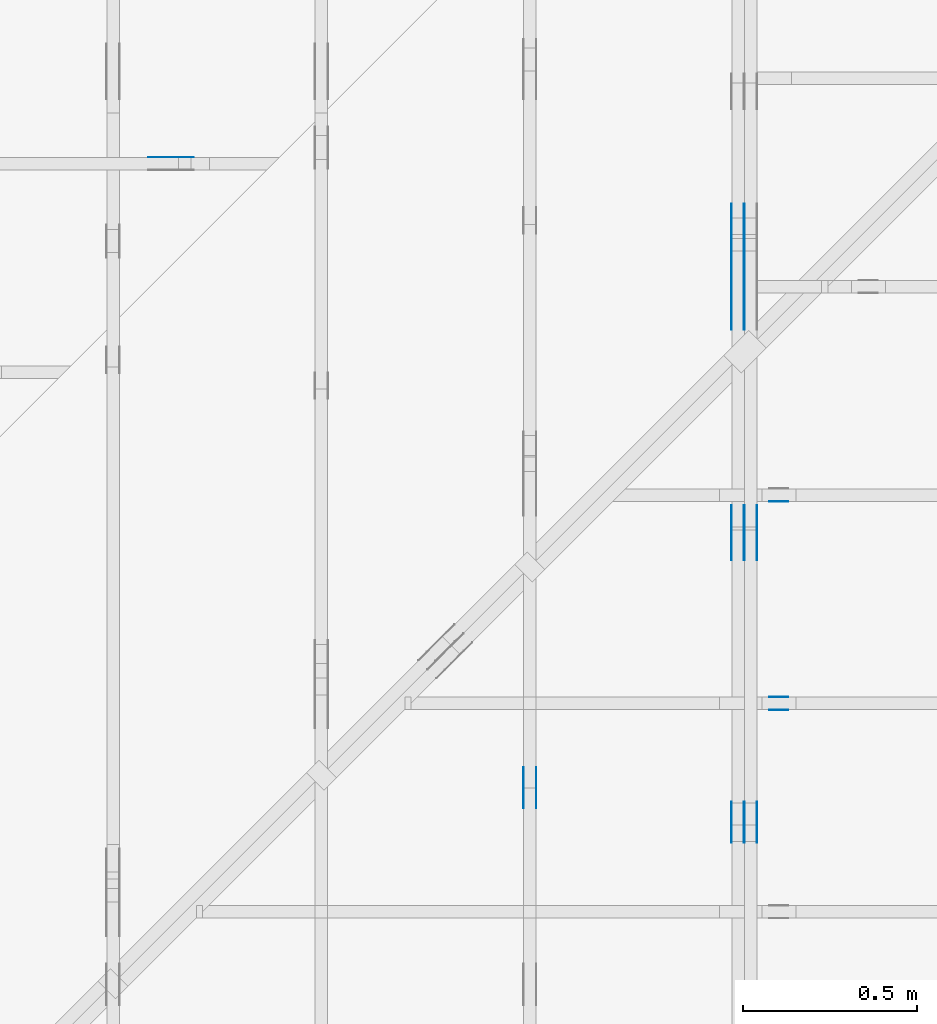
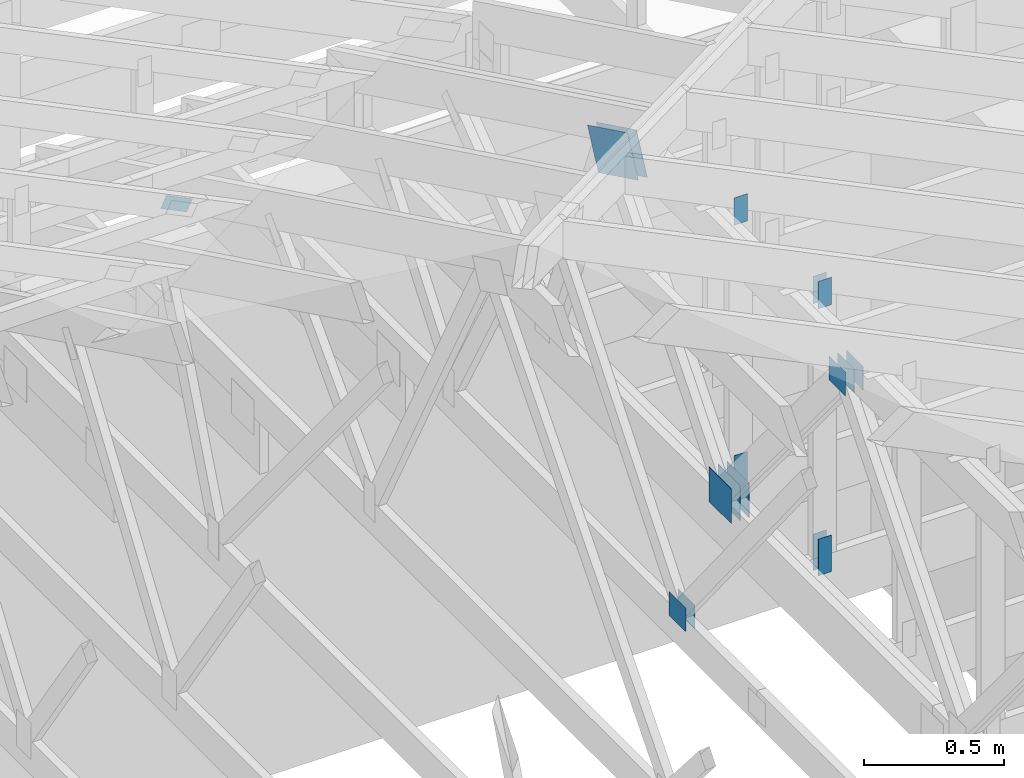
# One storey, part 123 of 159: 20 plates, 5 elements without a shape of their own.
"""IFC2X3 building model written with IfcOpenShell, lengths in millimetres."""

from ifc_helpers import new_model, si_unit, frame, origin, origin_with_axes, origin_2d, place, context, project, spatial, faceted_brep, element, aggregate, save


model = new_model("IFC2X3")

# Units and contexts
model_context = context("Model", 3, precision=1e-05, world=origin())
plan_context = context("Plan", 2, precision=1e-05, world=origin_2d())
ifc_project = project(units=[si_unit("LENGTHUNIT", "METRE", prefix="MILLI"), si_unit("AREAUNIT", "SQUARE_METRE"), si_unit("VOLUMEUNIT", "CUBIC_METRE"), si_unit("SOLIDANGLEUNIT", "STERADIAN"), si_unit("PLANEANGLEUNIT", "RADIAN"), si_unit("MASSUNIT", "GRAM"), si_unit("TIMEUNIT", "SECOND"), si_unit("THERMODYNAMICTEMPERATUREUNIT", "DEGREE_CELSIUS"), si_unit("LUMINOUSINTENSITYUNIT", "LUMEN")], contexts=[model_context, plan_context])

# Site, building, storey
site_placement = place(None, origin_with_axes())
site = spatial("IfcSite", under=ifc_project, at=site_placement, CompositionType="ELEMENT")
building_placement = place(site_placement, origin_with_axes())
building = spatial("IfcBuilding", under=site, at=building_placement, Name="Plan 1", CompositionType="ELEMENT")
storey_placement = place(building_placement, origin_with_axes())
storey = spatial("IfcBuildingStorey", under=building, at=storey_placement, Name="Etasje 1", CompositionType="ELEMENT", Elevation=0.0)

# Assembly, plates
assembly_1_placement = place(storey_placement, frame((18074.541652722903, -699.9989301294845, 4.408582873760558e-15), z_axis=(-1.0, 1.836909530733566e-16, 6.123031769111886e-17), x_axis=(-1.836909530733566e-16, -1.0, 0.0)))
assembly_1 = element("IfcElementAssembly", 1, at=assembly_1_placement, inside=storey, Name="V5 (30)", AssemblyPlace="FACTORY", PredefinedType="TRUSS")
plate_1_placement = place(assembly_1_placement, frame((-7760.342449781897, 1100.3683279098323, 0.0), z_axis=(0.0, 0.0, 1.0), x_axis=(0.898794046299167, 0.4383711467890773, 0.0)))
plate_1 = element("IfcPlate", 2, at=plate_1_placement, Name="GNT100S 178x317", context=model_context, shape_type="Brep", body=[
    faceted_brep([(317.00021679317524, 178.00010193051548, 1.0), (0.0, 178.00010193051548, 1.0), (0.0001831628151194309, 0.0, 1.0), (316.99996109170934, 0.0, 1.0), (0.0, 178.00010193051548, 0.0), (317.00021679317524, 178.00010193051548, 3.8820047964799344e-14), (316.99996109170934, 7.439335240633227e-05, 3.882001665143536e-14), (0.0001831628151194309, 7.439335240633227e-05, 2.2430234717924845e-20), (317.00013586756086, 2.211403892577016e-05, 3.565444953784189e-30), (317.00013586756086, 2.211403892583139e-05, 1.0), (0.00013586755994765554, 2.2114038984061424e-05, 1.0), (0.00013586755994765554, 2.2114038984000193e-05, 1.504632769052528e-36), (317.00013586756086, 178.00002211403898, 0.0), (317.00013586756086, 178.00002211403898, 1.0), (317.00013586756086, 2.2114038984000217e-05, 1.0), (317.00013586756086, 2.2114038984000217e-05, 0.0), (0.00013586756085715024, 178.00002211403898, 0.0), (0.00013586756085715024, 178.00002211403898, 1.0), (317.00013586756086, 178.00002211403896, 1.0), (317.00013586756086, 178.00002211403896, -1.5777218104420236e-30), (0.00013586755994765554, 2.2114038984000217e-05, -1.504632769052528e-36), (0.00013586755994771677, 2.2114038984000217e-05, 1.0), (0.00013586756083904143, 178.00002211403898, 1.0), (0.0001358675608389802, 178.00002211403898, 1.1125555620928203e-30)], [[[0, 1, 2, 3]], [[4, 5, 6, 7]], [[8, 9, 10, 11]], [[12, 13, 14, 15]], [[16, 17, 18, 19]], [[20, 21, 22, 23]]]),
])
plate_2_placement = place(assembly_1_placement, frame((-7760.342449781897, 1100.3683279098323, -37.0), z_axis=(0.0, 0.0, 1.0), x_axis=(0.898794046299167, 0.4383711467890773, 0.0)))
plate_2 = element("IfcPlate", 3, at=plate_2_placement, Name="GNT100S 178x317", context=model_context, shape_type="Brep", body=[
    faceted_brep([(317.00021679317524, 178.00010193051548, 1.0), (0.0, 178.00010193051548, 1.0), (0.0001831628151194309, 0.0, 1.0), (316.99996109170934, 0.0, 1.0), (0.0, 178.00010193051548, 0.0), (317.00021679317524, 178.00010193051548, 3.8820047964799344e-14), (316.99996109170934, 7.439335240633227e-05, 3.882001665143536e-14), (0.0001831628151194309, 7.439335240633227e-05, 2.2430234717924845e-20), (317.00013586756086, 2.211403892577016e-05, 3.565444953784189e-30), (317.00013586756086, 2.211403892583139e-05, 1.0), (0.00013586755994765554, 2.2114038984061424e-05, 1.0), (0.00013586755994765554, 2.2114038984000193e-05, 1.504632769052528e-36), (317.00013586756086, 178.00002211403898, 0.0), (317.00013586756086, 178.00002211403898, 1.0), (317.00013586756086, 2.2114038984000217e-05, 1.0), (317.00013586756086, 2.2114038984000217e-05, 0.0), (0.00013586756085715024, 178.00002211403898, 0.0), (0.00013586756085715024, 178.00002211403898, 1.0), (317.00013586756086, 178.00002211403896, 1.0), (317.00013586756086, 178.00002211403896, -1.5777218104420236e-30), (0.00013586755994765554, 2.2114038984000217e-05, -1.504632769052528e-36), (0.00013586755994771677, 2.2114038984000217e-05, 1.0), (0.00013586756083904143, 178.00002211403898, 1.0), (0.0001358675608389802, 178.00002211403898, 1.1125555620928203e-30)], [[[0, 1, 2, 3]], [[4, 5, 6, 7]], [[8, 9, 10, 11]], [[12, 13, 14, 15]], [[16, 17, 18, 19]], [[20, 21, 22, 23]]]),
])
plate_3_placement = place(assembly_1_placement, frame((-7760.342449781897, 1100.3683279098323, -36.0), z_axis=(0.0, 0.0, 1.0), x_axis=(0.898794046299167, 0.4383711467890773, 0.0)))
plate_3 = element("IfcPlate", 4, at=plate_3_placement, Name="GNT100S 178x317", context=model_context, shape_type="Brep", body=[
    faceted_brep([(317.00021679317524, 178.00010193051548, 1.0), (0.0, 178.00010193051548, 1.0), (0.0001831628151194309, 0.0, 1.0), (316.99996109170934, 0.0, 1.0), (0.0, 178.00010193051548, 0.0), (317.00021679317524, 178.00010193051548, 3.8820047964799344e-14), (316.99996109170934, 7.439335240633227e-05, 3.882001665143536e-14), (0.0001831628151194309, 7.439335240633227e-05, 2.2430234717924845e-20), (317.00013586756086, 2.211403892577016e-05, 3.565444953784189e-30), (317.00013586756086, 2.211403892583139e-05, 1.0), (0.00013586755994765554, 2.2114038984061424e-05, 1.0), (0.00013586755994765554, 2.2114038984000193e-05, 1.504632769052528e-36), (317.00013586756086, 178.00002211403898, 0.0), (317.00013586756086, 178.00002211403898, 1.0), (317.00013586756086, 2.2114038984000217e-05, 1.0), (317.00013586756086, 2.2114038984000217e-05, 0.0), (0.00013586756085715024, 178.00002211403898, 0.0), (0.00013586756085715024, 178.00002211403898, 1.0), (317.00013586756086, 178.00002211403896, 1.0), (317.00013586756086, 178.00002211403896, -1.5777218104420236e-30), (0.00013586755994765554, 2.2114038984000217e-05, -1.504632769052528e-36), (0.00013586755994771677, 2.2114038984000217e-05, 1.0), (0.00013586756083904143, 178.00002211403898, 1.0), (0.0001358675608389802, 178.00002211403898, 1.1125555620928203e-30)], [[[0, 1, 2, 3]], [[4, 5, 6, 7]], [[8, 9, 10, 11]], [[12, 13, 14, 15]], [[16, 17, 18, 19]], [[20, 21, 22, 23]]]),
])
plate_4_placement = place(assembly_1_placement, frame((-5998.6103515625, 1299.3388977633392, 0.0), z_axis=(0.0, 0.0, 1.0), x_axis=(-1.0, 1.2246063538223773e-16, 0.0)))
plate_4 = element("IfcPlate", 5, at=plate_4_placement, Name="GNT100S 103x119", context=model_context, shape_type="Brep", body=[
    faceted_brep([(119.0, 103.00003057583922, 1.0), (0.0, 103.00003057583922, 1.0), (0.0, 3.0575839218727197e-05, 1.0), (119.0, 3.0575839218727197e-05, 1.0), (0.0, 103.00003057583922, 0.0), (119.0, 103.00003057583922, 1.457281561048629e-14), (119.0, 3.0575839218727197e-05, 1.457281561048629e-14), (0.0, 3.0575839218727197e-05, 0.0), (119.00022782940414, -2.1859265265929818e-14, 1.3384497567273226e-30), (119.00022782940414, -2.17980349482387e-14, 1.0), (0.00022782940413890174, 6.118846749073445e-17, 1.0), (0.00022782940413890174, -4.185020038440979e-20, 2.5625010649743963e-36), (119.00022782940414, 103.0, 0.0), (119.00022782940414, 103.0, 1.0), (119.00022782940414, 0.0, 1.0), (119.00022782940414, 0.0, 0.0), (0.00022782940413890174, 103.0, 0.0), (0.00022782940413890174, 103.0, 1.0), (119.00022782940414, 102.99999999999999, 1.0), (119.00022782940414, 102.99999999999999, -7.888609052210118e-31), (0.00022782940413890174, 0.0, 0.0), (0.00022782940413896297, -7.498303609110687e-33, 1.0), (0.0002278294041515764, 103.0, 1.0), (0.00022782940415151518, 103.0, -7.723249910891245e-31)], [[[0, 1, 2, 3]], [[4, 5, 6, 7]], [[8, 9, 10, 11]], [[12, 13, 14, 15]], [[16, 17, 18, 19]], [[20, 21, 22, 23]]]),
])
plate_5_placement = place(assembly_1_placement, frame((-5998.6103515625, 1299.3388977633392, -37.0), z_axis=(0.0, 0.0, 1.0), x_axis=(-1.0, 1.2246063538223773e-16, 0.0)))
plate_5 = element("IfcPlate", 6, at=plate_5_placement, Name="GNT100S 103x119", context=model_context, shape_type="Brep", body=[
    faceted_brep([(119.0, 103.00003057583922, 1.0), (0.0, 103.00003057583922, 1.0), (0.0, 3.0575839218727197e-05, 1.0), (119.0, 3.0575839218727197e-05, 1.0), (0.0, 103.00003057583922, 0.0), (119.0, 103.00003057583922, 1.457281561048629e-14), (119.0, 3.0575839218727197e-05, 1.457281561048629e-14), (0.0, 3.0575839218727197e-05, 0.0), (119.00022782940414, -2.1859265265929818e-14, 1.3384497567273226e-30), (119.00022782940414, -2.17980349482387e-14, 1.0), (0.00022782940413890174, 6.118846749073445e-17, 1.0), (0.00022782940413890174, -4.185020038440979e-20, 2.5625010649743963e-36), (119.00022782940414, 103.0, 0.0), (119.00022782940414, 103.0, 1.0), (119.00022782940414, 0.0, 1.0), (119.00022782940414, 0.0, 0.0), (0.00022782940413890174, 103.0, 0.0), (0.00022782940413890174, 103.0, 1.0), (119.00022782940414, 102.99999999999999, 1.0), (119.00022782940414, 102.99999999999999, -7.888609052210118e-31), (0.00022782940413890174, 0.0, 0.0), (0.00022782940413896297, -7.498303609110687e-33, 1.0), (0.0002278294041515764, 103.0, 1.0), (0.00022782940415151518, 103.0, -7.723249910891245e-31)], [[[0, 1, 2, 3]], [[4, 5, 6, 7]], [[8, 9, 10, 11]], [[12, 13, 14, 15]], [[16, 17, 18, 19]], [[20, 21, 22, 23]]]),
])
plate_6_placement = place(assembly_1_placement, frame((-5998.6103515625, 1299.3388977633392, -36.0), z_axis=(0.0, 0.0, 1.0), x_axis=(-1.0, 1.2246063538223773e-16, 0.0)))
plate_6 = element("IfcPlate", 7, at=plate_6_placement, Name="GNT100S 103x119", context=model_context, shape_type="Brep", body=[
    faceted_brep([(119.0, 103.00003057583922, 1.0), (0.0, 103.00003057583922, 1.0), (0.0, 3.0575839218727197e-05, 1.0), (119.0, 3.0575839218727197e-05, 1.0), (0.0, 103.00003057583922, 0.0), (119.0, 103.00003057583922, 1.457281561048629e-14), (119.0, 3.0575839218727197e-05, 1.457281561048629e-14), (0.0, 3.0575839218727197e-05, 0.0), (119.00022782940414, -2.1859265265929818e-14, 1.3384497567273226e-30), (119.00022782940414, -2.17980349482387e-14, 1.0), (0.00022782940413890174, 6.118846749073445e-17, 1.0), (0.00022782940413890174, -4.185020038440979e-20, 2.5625010649743963e-36), (119.00022782940414, 103.0, 0.0), (119.00022782940414, 103.0, 1.0), (119.00022782940414, 0.0, 1.0), (119.00022782940414, 0.0, 0.0), (0.00022782940413890174, 103.0, 0.0), (0.00022782940413890174, 103.0, 1.0), (119.00022782940414, 102.99999999999999, 1.0), (119.00022782940414, 102.99999999999999, -7.888609052210118e-31), (0.00022782940413890174, 0.0, 0.0), (0.00022782940413896297, -7.498303609110687e-33, 1.0), (0.0002278294041515764, 103.0, 1.0), (0.00022782940415151518, 103.0, -7.723249910891245e-31)], [[[0, 1, 2, 3]], [[4, 5, 6, 7]], [[8, 9, 10, 11]], [[12, 13, 14, 15]], [[16, 17, 18, 19]], [[20, 21, 22, 23]]]),
])
plate_7_placement = place(assembly_1_placement, frame((-5998.6103515625, 1299.3388977633392, -73.0), z_axis=(0.0, 0.0, 1.0), x_axis=(-1.0, 1.2246063538223773e-16, 0.0)))
plate_7 = element("IfcPlate", 8, at=plate_7_placement, Name="GNT100S 103x119", context=model_context, shape_type="Brep", body=[
    faceted_brep([(119.0, 103.00003057583922, 1.0), (0.0, 103.00003057583922, 1.0), (0.0, 3.0575839218727197e-05, 1.0), (119.0, 3.0575839218727197e-05, 1.0), (0.0, 103.00003057583922, 0.0), (119.0, 103.00003057583922, 1.457281561048629e-14), (119.0, 3.0575839218727197e-05, 1.457281561048629e-14), (0.0, 3.0575839218727197e-05, 0.0), (119.00022782940414, -2.1859265265929818e-14, 1.3384497567273226e-30), (119.00022782940414, -2.17980349482387e-14, 1.0), (0.00022782940413890174, 6.118846749073445e-17, 1.0), (0.00022782940413890174, -4.185020038440979e-20, 2.5625010649743963e-36), (119.00022782940414, 103.0, 0.0), (119.00022782940414, 103.0, 1.0), (119.00022782940414, 0.0, 1.0), (119.00022782940414, 0.0, 0.0), (0.00022782940413890174, 103.0, 0.0), (0.00022782940413890174, 103.0, 1.0), (119.00022782940414, 102.99999999999999, 1.0), (119.00022782940414, 102.99999999999999, -7.888609052210118e-31), (0.00022782940413890174, 0.0, 0.0), (0.00022782940413896297, -7.498303609110687e-33, 1.0), (0.0002278294041515764, 103.0, 1.0), (0.00022782940415151518, 103.0, -7.723249910891245e-31)], [[[0, 1, 2, 3]], [[4, 5, 6, 7]], [[8, 9, 10, 11]], [[12, 13, 14, 15]], [[16, 17, 18, 19]], [[20, 21, 22, 23]]]),
])
plate_8_placement = place(assembly_1_placement, frame((-6971.361930196468, 146.9999999999996, 0.0), z_axis=(0.0, 0.0, 1.0), x_axis=(1.0, 0.0, 0.0)))
plate_8 = element("IfcPlate", 9, at=plate_8_placement, Name="GNT100S 152x159", context=model_context, shape_type="Brep", body=[
    faceted_brep([(159.00011379021817, 152.0000000000004, 1.0), (0.00011379021816537715, 152.0000000000004, 1.0), (0.00011379021816537715, 3.979039320256561e-13, 1.0), (159.00011379021817, 3.979039320256561e-13, 1.0), (0.00011379021816537715, 152.0000000000004, 1.3934822416815536e-20), (159.00011379021817, 152.0000000000004, 1.9471254960598215e-14), (159.00011379021817, 3.979039320256561e-13, 1.9471254960598215e-14), (0.00011379021816537715, 3.979039320256561e-13, 1.3934822416815536e-20), (159.0, -2.92068615386637e-14, 1.788345410772899e-30), (159.0, -2.914563122097258e-14, 1.0), (1.1247455413666031e-32, 6.123031769111886e-17, 1.0), (0.0, 0.0, 0.0), (159.0, 152.0, 0.0), (159.0, 152.0, 1.0), (159.0, 0.0, 1.0), (159.0, 0.0, 0.0), (0.0, 152.0, 0.0), (-3.7491518045553436e-33, 152.0, 1.0), (159.0, 152.0, 1.0), (159.0, 152.0, 0.0), (0.0, 0.0, 0.0), (6.123031769111886e-17, -7.498303609110687e-33, 1.0), (1.8675246895791253e-14, 152.0, 1.0), (1.8614016578100134e-14, 152.0, -1.1397421485848245e-30)], [[[0, 1, 2, 3]], [[4, 5, 6, 7]], [[8, 9, 10, 11]], [[12, 13, 14, 15]], [[16, 17, 18, 19]], [[20, 21, 22, 23]]]),
])
plate_9_placement = place(assembly_1_placement, frame((-6971.361930196468, 146.9999999999996, -37.0), z_axis=(0.0, 0.0, 1.0), x_axis=(1.0, 0.0, 0.0)))
plate_9 = element("IfcPlate", 10, at=plate_9_placement, Name="GNT100S 152x159", context=model_context, shape_type="Brep", body=[
    faceted_brep([(159.00011379021817, 152.0000000000004, 1.0), (0.00011379021816537715, 152.0000000000004, 1.0), (0.00011379021816537715, 3.979039320256561e-13, 1.0), (159.00011379021817, 3.979039320256561e-13, 1.0), (0.00011379021816537715, 152.0000000000004, 1.3934822416815536e-20), (159.00011379021817, 152.0000000000004, 1.9471254960598215e-14), (159.00011379021817, 3.979039320256561e-13, 1.9471254960598215e-14), (0.00011379021816537715, 3.979039320256561e-13, 1.3934822416815536e-20), (159.0, -2.92068615386637e-14, 1.788345410772899e-30), (159.0, -2.914563122097258e-14, 1.0), (1.1247455413666031e-32, 6.123031769111886e-17, 1.0), (0.0, 0.0, 0.0), (159.0, 152.0, 0.0), (159.0, 152.0, 1.0), (159.0, 0.0, 1.0), (159.0, 0.0, 0.0), (0.0, 152.0, 0.0), (-3.7491518045553436e-33, 152.0, 1.0), (159.0, 152.0, 1.0), (159.0, 152.0, 0.0), (0.0, 0.0, 0.0), (6.123031769111886e-17, -7.498303609110687e-33, 1.0), (1.8675246895791253e-14, 152.0, 1.0), (1.8614016578100134e-14, 152.0, -1.1397421485848245e-30)], [[[0, 1, 2, 3]], [[4, 5, 6, 7]], [[8, 9, 10, 11]], [[12, 13, 14, 15]], [[16, 17, 18, 19]], [[20, 21, 22, 23]]]),
])
plate_10_placement = place(assembly_1_placement, frame((-6971.361930196468, 146.9999999999996, -36.0), z_axis=(0.0, 0.0, 1.0), x_axis=(1.0, 0.0, 0.0)))
plate_10 = element("IfcPlate", 11, at=plate_10_placement, Name="GNT100S 152x159", context=model_context, shape_type="Brep", body=[
    faceted_brep([(159.00011379021817, 152.0000000000004, 1.0), (0.00011379021816537715, 152.0000000000004, 1.0), (0.00011379021816537715, 3.979039320256561e-13, 1.0), (159.00011379021817, 3.979039320256561e-13, 1.0), (0.00011379021816537715, 152.0000000000004, 1.3934822416815536e-20), (159.00011379021817, 152.0000000000004, 1.9471254960598215e-14), (159.00011379021817, 3.979039320256561e-13, 1.9471254960598215e-14), (0.00011379021816537715, 3.979039320256561e-13, 1.3934822416815536e-20), (159.0, -2.92068615386637e-14, 1.788345410772899e-30), (159.0, -2.914563122097258e-14, 1.0), (1.1247455413666031e-32, 6.123031769111886e-17, 1.0), (0.0, 0.0, 0.0), (159.0, 152.0, 0.0), (159.0, 152.0, 1.0), (159.0, 0.0, 1.0), (159.0, 0.0, 0.0), (0.0, 152.0, 0.0), (-3.7491518045553436e-33, 152.0, 1.0), (159.0, 152.0, 1.0), (159.0, 152.0, 0.0), (0.0, 0.0, 0.0), (6.123031769111886e-17, -7.498303609110687e-33, 1.0), (1.8675246895791253e-14, 152.0, 1.0), (1.8614016578100134e-14, 152.0, -1.1397421485848245e-30)], [[[0, 1, 2, 3]], [[4, 5, 6, 7]], [[8, 9, 10, 11]], [[12, 13, 14, 15]], [[16, 17, 18, 19]], [[20, 21, 22, 23]]]),
])
plate_11_placement = place(assembly_1_placement, frame((-6971.361930196468, 146.9999999999996, -73.0), z_axis=(0.0, 0.0, 1.0), x_axis=(1.0, 0.0, 0.0)))
plate_11 = element("IfcPlate", 12, at=plate_11_placement, Name="GNT100S 152x159", context=model_context, shape_type="Brep", body=[
    faceted_brep([(159.00011379021817, 152.0000000000004, 1.0), (0.00011379021816537715, 152.0000000000004, 1.0), (0.00011379021816537715, 3.979039320256561e-13, 1.0), (159.00011379021817, 3.979039320256561e-13, 1.0), (0.00011379021816537715, 152.0000000000004, 1.3934822416815536e-20), (159.00011379021817, 152.0000000000004, 1.9471254960598215e-14), (159.00011379021817, 3.979039320256561e-13, 1.9471254960598215e-14), (0.00011379021816537715, 3.979039320256561e-13, 1.3934822416815536e-20), (159.0, -2.92068615386637e-14, 1.788345410772899e-30), (159.0, -2.914563122097258e-14, 1.0), (1.1247455413666031e-32, 6.123031769111886e-17, 1.0), (0.0, 0.0, 0.0), (159.0, 152.0, 0.0), (159.0, 152.0, 1.0), (159.0, 0.0, 1.0), (159.0, 0.0, 0.0), (0.0, 152.0, 0.0), (-3.7491518045553436e-33, 152.0, 1.0), (159.0, 152.0, 1.0), (159.0, 152.0, 0.0), (0.0, 0.0, 0.0), (6.123031769111886e-17, -7.498303609110687e-33, 1.0), (1.8675246895791253e-14, 152.0, 1.0), (1.8614016578100134e-14, 152.0, -1.1397421485848245e-30)], [[[0, 1, 2, 3]], [[4, 5, 6, 7]], [[8, 9, 10, 11]], [[12, 13, 14, 15]], [[16, 17, 18, 19]], [[20, 21, 22, 23]]]),
])
aggregate(assembly_1, [plate_1, plate_2, plate_3, plate_4, plate_5, plate_6, plate_7, plate_8, plate_9, plate_10, plate_11])

assembly_2_placement = place(storey_placement, frame((17475.02226140475, -699.9989301294827, 1.1021457184401395e-15), z_axis=(-1.0, 1.836909530733566e-16, 6.123031769111886e-17), x_axis=(-1.836909530733566e-16, -1.0, 0.0)))
assembly_2 = element("IfcElementAssembly", 13, at=assembly_2_placement, inside=storey, Name="V6 (31)", AssemblyPlace="FACTORY", PredefinedType="TRUSS")
plate_12_placement = place(assembly_2_placement, frame((-6216.7265625, 319.4999999999995, 0.0), z_axis=(0.0, 0.0, 1.0), x_axis=(1.0, 0.0, 0.0)))
plate_12 = element("IfcPlate", 14, at=plate_12_placement, Name="GNT100S 103x119", context=model_context, shape_type="Brep", body=[
    faceted_brep([(119.0, 103.00000000000051, 1.0), (0.0, 103.00000000000051, 1.0), (0.0, 5.115907697472721e-13, 1.0), (119.0, 5.115907697472721e-13, 1.0), (0.0, 103.00000000000051, 0.0), (119.0, 103.00000000000051, 1.457281561048629e-14), (119.0, 5.115907697472721e-13, 1.457281561048629e-14), (0.0, 5.115907697472721e-13, 0.0), (119.0000814742234, -2.1859238381807182e-14, 1.3384481106039528e-30), (119.0000814742234, -2.1798008064116063e-14, 1.0), (8.14742234069854e-05, 6.121535161337032e-17, 1.0), (8.14742234069854e-05, -1.4966077748540726e-20, 9.163776951331336e-37), (119.0000814742234, 103.0, 0.0), (119.0000814742234, 103.0, 1.0), (119.0000814742234, 0.0, 1.0), (119.0000814742234, 0.0, 0.0), (8.14742234069854e-05, 103.0, 0.0), (8.14742234069854e-05, 103.0, 1.0), (119.0000814742234, 102.99999999999999, 1.0), (119.0000814742234, 102.99999999999999, -7.888609052210118e-31), (8.14742234069854e-05, 0.0, 0.0), (8.147422340704663e-05, -7.498303609110687e-33, 1.0), (8.147422341966008e-05, 103.0, 1.0), (8.147422341959885e-05, 103.0, -7.723249910891245e-31)], [[[0, 1, 2, 3]], [[4, 5, 6, 7]], [[8, 9, 10, 11]], [[12, 13, 14, 15]], [[16, 17, 18, 19]], [[20, 21, 22, 23]]]),
])
plate_13_placement = place(assembly_2_placement, frame((-6216.7265625, 319.4999999999995, -37.0), z_axis=(0.0, 0.0, 1.0), x_axis=(1.0, 0.0, 0.0)))
plate_13 = element("IfcPlate", 15, at=plate_13_placement, Name="GNT100S 103x119", context=model_context, shape_type="Brep", body=[
    faceted_brep([(119.0, 103.00000000000051, 1.0), (0.0, 103.00000000000051, 1.0), (0.0, 5.115907697472721e-13, 1.0), (119.0, 5.115907697472721e-13, 1.0), (0.0, 103.00000000000051, 0.0), (119.0, 103.00000000000051, 1.457281561048629e-14), (119.0, 5.115907697472721e-13, 1.457281561048629e-14), (0.0, 5.115907697472721e-13, 0.0), (119.0000814742234, -2.1859238381807182e-14, 1.3384481106039528e-30), (119.0000814742234, -2.1798008064116063e-14, 1.0), (8.14742234069854e-05, 6.121535161337032e-17, 1.0), (8.14742234069854e-05, -1.4966077748540726e-20, 9.163776951331336e-37), (119.0000814742234, 103.0, 0.0), (119.0000814742234, 103.0, 1.0), (119.0000814742234, 0.0, 1.0), (119.0000814742234, 0.0, 0.0), (8.14742234069854e-05, 103.0, 0.0), (8.14742234069854e-05, 103.0, 1.0), (119.0000814742234, 102.99999999999999, 1.0), (119.0000814742234, 102.99999999999999, -7.888609052210118e-31), (8.14742234069854e-05, 0.0, 0.0), (8.147422340704663e-05, -7.498303609110687e-33, 1.0), (8.147422341966008e-05, 103.0, 1.0), (8.147422341959885e-05, 103.0, -7.723249910891245e-31)], [[[0, 1, 2, 3]], [[4, 5, 6, 7]], [[8, 9, 10, 11]], [[12, 13, 14, 15]], [[16, 17, 18, 19]], [[20, 21, 22, 23]]]),
])
aggregate(assembly_2, [plate_12, plate_13])

assembly_3_placement = place(storey_placement, frame((21100.012663101486, 5717.993668449257, 1.1021457184401395e-15), z_axis=(1.2246063538223773e-16, 1.0, 6.123031769111886e-17), x_axis=(-1.0, 1.2246063538223773e-16, 0.0)))
assembly_3 = element("IfcElementAssembly", 16, at=assembly_3_placement, inside=storey, Name="S15 (47)", AssemblyPlace="FACTORY", PredefinedType="TRUSS")
plate_14_placement = place(assembly_3_placement, frame((2862.490401698563, 1424.37744140625, 0.0), z_axis=(0.0, 0.0, 1.0), x_axis=(6.123031769111886e-17, -1.0, 0.0)))
plate_14 = element("IfcPlate", 17, at=plate_14_placement, Name="GNT100S 55x119", context=model_context, shape_type="Brep", body=[
    faceted_brep([(119.0, 55.00007681706211, 1.0), (0.0, 55.00007681706211, 1.0), (0.0, 7.681706210860284e-05, 1.0), (119.0, 7.681706210860284e-05, 1.0), (0.0, 55.00007681706211, 0.0), (119.0, 55.00007681706211, 1.457281561048629e-14), (119.0, 7.681706210860284e-05, 1.457281561048629e-14), (0.0, 7.681706210860284e-05, 0.0), (119.00002904577786, -2.1859228751176052e-14, 1.3384475209173491e-30), (119.00002904577786, -2.1797998433484933e-14, 1.0), (2.904577786466689e-05, 6.122498224450015e-17, 1.0), (2.904577786466689e-05, -5.335446618717665e-21, 3.2669109148808856e-37), (119.00002904577786, 55.0, 0.0), (119.00002904577786, 55.0, 1.0), (119.00002904577786, 0.0, 1.0), (119.00002904577786, 0.0, 0.0), (2.904577786466689e-05, 55.0, 0.0), (2.904577786466689e-05, 55.0, 1.0), (119.00002904577786, 54.99999999999999, 1.0), (119.00002904577786, 54.99999999999999, -3.944304526105059e-31), (2.904577786466689e-05, 0.0, 0.0), (2.904577786472812e-05, -7.498303609110687e-33, 1.0), (2.9045777871463454e-05, 55.0, 1.0), (2.9045777871402223e-05, 55.0, -4.124066764605687e-31)], [[[0, 1, 2, 3]], [[4, 5, 6, 7]], [[8, 9, 10, 11]], [[12, 13, 14, 15]], [[16, 17, 18, 19]], [[20, 21, 22, 23]]]),
])
plate_15_placement = place(assembly_3_placement, frame((2862.490401698563, 1424.37744140625, -37.0), z_axis=(0.0, 0.0, 1.0), x_axis=(6.123031769111886e-17, -1.0, 0.0)))
plate_15 = element("IfcPlate", 18, at=plate_15_placement, Name="GNT100S 55x119", context=model_context, shape_type="Brep", body=[
    faceted_brep([(119.0, 55.00007681706211, 1.0), (0.0, 55.00007681706211, 1.0), (0.0, 7.681706210860284e-05, 1.0), (119.0, 7.681706210860284e-05, 1.0), (0.0, 55.00007681706211, 0.0), (119.0, 55.00007681706211, 1.457281561048629e-14), (119.0, 7.681706210860284e-05, 1.457281561048629e-14), (0.0, 7.681706210860284e-05, 0.0), (119.00002904577786, -2.1859228751176052e-14, 1.3384475209173491e-30), (119.00002904577786, -2.1797998433484933e-14, 1.0), (2.904577786466689e-05, 6.122498224450015e-17, 1.0), (2.904577786466689e-05, -5.335446618717665e-21, 3.2669109148808856e-37), (119.00002904577786, 55.0, 0.0), (119.00002904577786, 55.0, 1.0), (119.00002904577786, 0.0, 1.0), (119.00002904577786, 0.0, 0.0), (2.904577786466689e-05, 55.0, 0.0), (2.904577786466689e-05, 55.0, 1.0), (119.00002904577786, 54.99999999999999, 1.0), (119.00002904577786, 54.99999999999999, -3.944304526105059e-31), (2.904577786466689e-05, 0.0, 0.0), (2.904577786472812e-05, -7.498303609110687e-33, 1.0), (2.9045777871463454e-05, 55.0, 1.0), (2.9045777871402223e-05, 55.0, -4.124066764605687e-31)], [[[0, 1, 2, 3]], [[4, 5, 6, 7]], [[8, 9, 10, 11]], [[12, 13, 14, 15]], [[16, 17, 18, 19]], [[20, 21, 22, 23]]]),
])
plate_16_placement = place(assembly_3_placement, frame((2917.490478515625, 143.5, 0.0), z_axis=(0.0, 0.0, 1.0), x_axis=(6.123031769111886e-17, 1.0, 0.0)))
plate_16 = element("IfcPlate", 19, at=plate_16_placement, Name="GNT100S 55x159", context=model_context, shape_type="Brep", body=[
    faceted_brep([(159.0, 55.0, 1.0), (0.0, 55.0, 1.0), (0.0, 0.0, 1.0), (159.0, 0.0, 1.0), (0.0, 55.0, 0.0), (159.0, 55.0, 1.9471241025775798e-14), (159.0, 0.0, 1.9471241025775798e-14), (0.0, 0.0, 0.0), (159.0, 7.681706480788008e-05, 1.788345571668688e-30), (159.0, 7.681706480794131e-05, 1.0), (1.1247455413666031e-32, 7.681706483714818e-05, 1.0), (0.0, 7.681706483708695e-05, 0.0), (159.0, 55.00007681706484, 0.0), (159.0, 55.00007681706484, 1.0), (159.0, 7.681706483708695e-05, 1.0), (159.0, 7.681706483708695e-05, 0.0), (-2.4308653429145085e-63, 55.00007681706484, 0.0), (-3.7491518045553436e-33, 55.00007681706484, 1.0), (159.0, 55.00007681706483, 1.0), (159.0, 55.00007681706483, -7.888609052210118e-31), (9.407066568148219e-21, 7.681706483708695e-05, -5.759976745092187e-37), (6.123972475768701e-17, 7.681706483708695e-05, 1.0), (6.796574670780762e-15, 55.00007681706484, 1.0), (6.7353443530896435e-15, 55.00007681706484, -4.124072744987623e-31)], [[[0, 1, 2, 3]], [[4, 5, 6, 7]], [[8, 9, 10, 11]], [[12, 13, 14, 15]], [[16, 17, 18, 19]], [[20, 21, 22, 23]]]),
])
plate_17_placement = place(assembly_3_placement, frame((2917.490478515625, 143.5, -37.0), z_axis=(0.0, 0.0, 1.0), x_axis=(6.123031769111886e-17, 1.0, 0.0)))
plate_17 = element("IfcPlate", 20, at=plate_17_placement, Name="GNT100S 55x159", context=model_context, shape_type="Brep", body=[
    faceted_brep([(159.0, 55.0, 1.0), (0.0, 55.0, 1.0), (0.0, 0.0, 1.0), (159.0, 0.0, 1.0), (0.0, 55.0, 0.0), (159.0, 55.0, 1.9471241025775798e-14), (159.0, 0.0, 1.9471241025775798e-14), (0.0, 0.0, 0.0), (159.0, 7.681706480788008e-05, 1.788345571668688e-30), (159.0, 7.681706480794131e-05, 1.0), (1.1247455413666031e-32, 7.681706483714818e-05, 1.0), (0.0, 7.681706483708695e-05, 0.0), (159.0, 55.00007681706484, 0.0), (159.0, 55.00007681706484, 1.0), (159.0, 7.681706483708695e-05, 1.0), (159.0, 7.681706483708695e-05, 0.0), (-2.4308653429145085e-63, 55.00007681706484, 0.0), (-3.7491518045553436e-33, 55.00007681706484, 1.0), (159.0, 55.00007681706483, 1.0), (159.0, 55.00007681706483, -7.888609052210118e-31), (9.407066568148219e-21, 7.681706483708695e-05, -5.759976745092187e-37), (6.123972475768701e-17, 7.681706483708695e-05, 1.0), (6.796574670780762e-15, 55.00007681706484, 1.0), (6.7353443530896435e-15, 55.00007681706484, -4.124072744987623e-31)], [[[0, 1, 2, 3]], [[4, 5, 6, 7]], [[8, 9, 10, 11]], [[12, 13, 14, 15]], [[16, 17, 18, 19]], [[20, 21, 22, 23]]]),
])
aggregate(assembly_3, [plate_14, plate_15, plate_16, plate_17])

assembly_4_placement = place(storey_placement, frame((21100.012663101486, 6317.993668449257, 1.1021457184401395e-15), z_axis=(1.2246063538223773e-16, 1.0, 6.123031769111886e-17), x_axis=(-1.0, 1.2246063538223773e-16, 0.0)))
assembly_4 = element("IfcElementAssembly", 21, at=assembly_4_placement, inside=storey, Name="S16 (45)", AssemblyPlace="FACTORY", PredefinedType="TRUSS")
plate_18_placement = place(assembly_4_placement, frame((2862.4904016985583, 1424.37744140625, -37.0), z_axis=(0.0, 0.0, 1.0), x_axis=(6.123031769111886e-17, -1.0, 0.0)))
plate_18 = element("IfcPlate", 22, at=plate_18_placement, Name="GNT100S 55x119", context=model_context, shape_type="Brep", body=[
    faceted_brep([(119.0, 55.000076817066656, 1.0), (0.0, 55.000076817066656, 1.0), (0.0, 7.681706665607635e-05, 1.0), (119.0, 7.681706665607635e-05, 1.0), (0.0, 55.000076817066656, 0.0), (119.0, 55.000076817066656, 1.457281561048629e-14), (119.0, 7.681706665607635e-05, 1.457281561048629e-14), (0.0, 7.681706665607635e-05, 0.0), (119.00002904680377, -2.1859228751364502e-14, 1.3384475209288881e-30), (119.00002904680377, -2.1797998433673383e-14, 1.0), (2.904680377469049e-05, 6.122498205604976e-17, 1.0), (2.904680377469049e-05, -5.3356350691076675e-21, 3.2670263036533743e-37), (119.00002904680377, 55.0, 0.0), (119.00002904680377, 55.0, 1.0), (119.00002904680377, 0.0, 1.0), (119.00002904680377, 0.0, 0.0), (2.904680377469049e-05, 55.0, 0.0), (2.904680377469049e-05, 55.0, 1.0), (119.00002904680377, 54.99999999999999, 1.0), (119.00002904680377, 54.99999999999999, -3.944304526105059e-31), (2.904680377469049e-05, 0.0, 0.0), (2.904680377475172e-05, -7.498303609110687e-33, 1.0), (2.9046803781487054e-05, 55.0, 1.0), (2.9046803781425823e-05, 55.0, -4.124066764605687e-31)], [[[0, 1, 2, 3]], [[4, 5, 6, 7]], [[8, 9, 10, 11]], [[12, 13, 14, 15]], [[16, 17, 18, 19]], [[20, 21, 22, 23]]]),
])
plate_19_placement = place(assembly_4_placement, frame((2917.490478515625, 143.5, -37.0), z_axis=(0.0, 0.0, 1.0), x_axis=(6.123031769111886e-17, 1.0, 0.0)))
plate_19 = element("IfcPlate", 23, at=plate_19_placement, Name="GNT100S 55x159", context=model_context, shape_type="Brep", body=[
    faceted_brep([(159.0, 55.0, 1.0), (0.0, 55.0, 1.0), (0.0, 0.0, 1.0), (159.0, 0.0, 1.0), (0.0, 55.0, 0.0), (159.0, 55.0, 1.9471241025775798e-14), (159.0, 0.0, 1.9471241025775798e-14), (0.0, 0.0, 0.0), (159.0, 7.681706480788008e-05, 1.788345571668688e-30), (159.0, 7.681706480794131e-05, 1.0), (1.1247455413666031e-32, 7.681706483714818e-05, 1.0), (0.0, 7.681706483708695e-05, 0.0), (159.0, 55.00007681706484, 0.0), (159.0, 55.00007681706484, 1.0), (159.0, 7.681706483708695e-05, 1.0), (159.0, 7.681706483708695e-05, 0.0), (-2.4308653429145085e-63, 55.00007681706484, 0.0), (-3.7491518045553436e-33, 55.00007681706484, 1.0), (159.0, 55.00007681706483, 1.0), (159.0, 55.00007681706483, -7.888609052210118e-31), (9.407066568148219e-21, 7.681706483708695e-05, -5.759976745092187e-37), (6.123972475768701e-17, 7.681706483708695e-05, 1.0), (6.796574670780762e-15, 55.00007681706484, 1.0), (6.7353443530896435e-15, 55.00007681706484, -4.124072744987623e-31)], [[[0, 1, 2, 3]], [[4, 5, 6, 7]], [[8, 9, 10, 11]], [[12, 13, 14, 15]], [[16, 17, 18, 19]], [[20, 21, 22, 23]]]),
])
aggregate(assembly_4, [plate_18, plate_19])

# Assembly, plate
assembly_5_placement = place(storey_placement, frame((12446.012607049342, 7236.0000560521385, 1312.9938842936408), z_axis=(0.0, -1.0, 6.123031769111886e-17), x_axis=(1.0, 0.0, 0.0)))
assembly_5 = element("IfcElementAssembly", 24, at=assembly_5_placement, inside=storey, Name="Tr3 (84)", AssemblyPlace="FACTORY", PredefinedType="TRUSS")
plate_20_placement = place(assembly_5_placement, frame((4078.826416015625, 87.8545837402346, -37.0), z_axis=(0.0, 0.0, 1.0), x_axis=(-0.8987940462991675, 0.4383711467890765, 0.0)))
plate_20 = element("IfcPlate", 25, at=plate_20_placement, Name="GNT100S 55x119", context=model_context, shape_type="Brep", body=[
    faceted_brep([(118.99998948302118, 55.000081238989424, 1.0), (0.0001635712847019022, 55.000081238989424, 1.0), (0.0, 0.0, 1.0), (119.00004701613034, 0.0, 1.0), (0.0001635712847019022, 55.000081238989424, 2.0031043454883843e-20), (118.99998948302118, 55.000081238989424, 1.457281432257038e-14), (119.00004701613034, 2.098981917697529e-05, 1.4572821368111483e-14), (0.0, 2.098981917697529e-05, 0.0), (119.00007991769235, 4.083752830953519e-05, 1.3384479605016376e-30), (119.00007991769235, 4.083752830959642e-05, 1.0), (7.991769234649837e-05, 4.083752833145564e-05, 1.0), (7.991769234649837e-05, 4.083752833139441e-05, 7.52316384526264e-37), (119.00007991769235, 55.000040837528104, 2.68212707775144e-29), (119.00007991769235, 55.000040837528104, 1.0), (119.00007991769235, 4.0837528331394424e-05, 1.0), (119.00007991769235, 4.0837528331394424e-05, 0.0), (7.991769234649836e-05, 55.00004083752833, 0.0), (7.991769234649836e-05, 55.00004083752833, 1.0), (119.00007991769189, 55.00004083752811, 1.0), (119.00007991769189, 55.00004083752811, 3.944304526105059e-31), (7.991769234649837e-05, 4.0837528331394424e-05, 0.0), (7.99176923465596e-05, 4.0837528331394424e-05, 1.0), (7.991769235329494e-05, 55.00004083752833, 1.0), (7.99176923532337e-05, 55.00004083752833, -4.12407052618761e-31)], [[[0, 1, 2, 3]], [[4, 5, 6, 7]], [[8, 9, 10, 11]], [[12, 13, 14, 15]], [[16, 17, 18, 19]], [[20, 21, 22, 23]]]),
])
aggregate(assembly_5, [plate_20])

save(model, "model.ifc")
